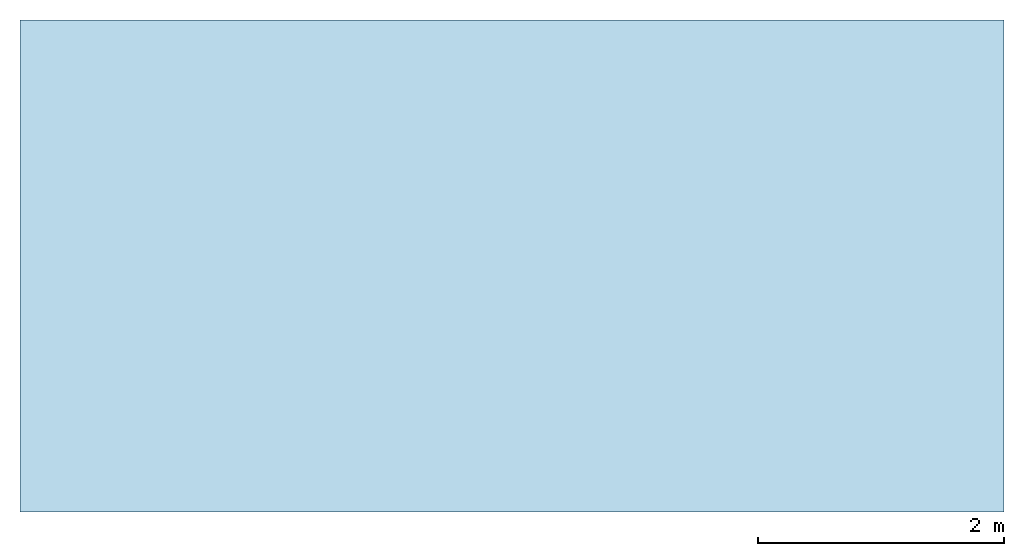
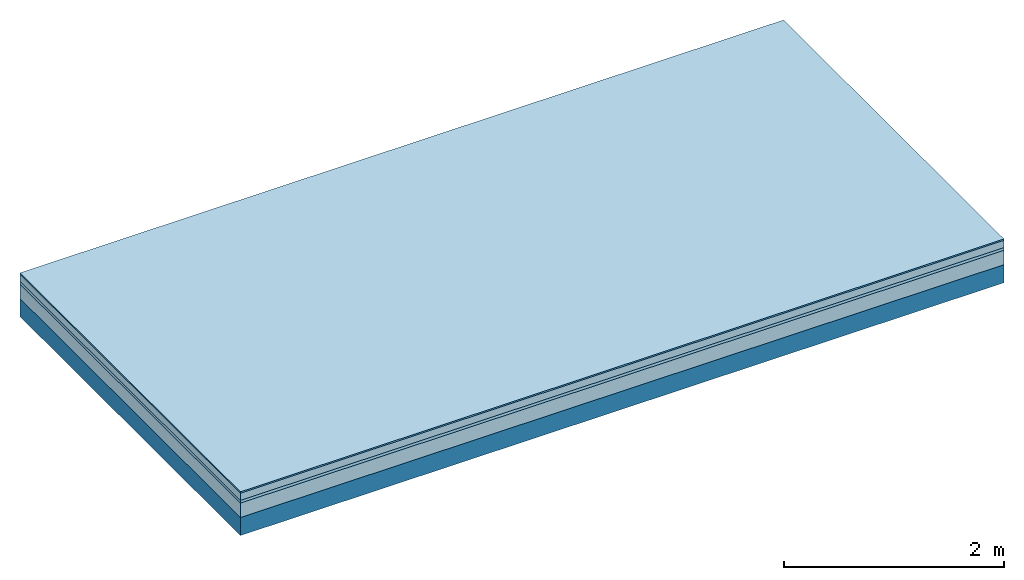
# One storey: 4 plates, 1 member, 1 element without a shape of its own.
"""IFC4 building model written with IfcOpenShell, lengths in metres."""

from ifc_helpers import new_model, si_unit, derived_unit, direction, frame, frame_2d, origin, origin_with_axes, place, context, project, spatial, rectangle, extrude, material, layer, layer_set, type_object, element, aggregate, save


model = new_model("IFC4")

# Units and contexts
plan_context = context("Plan", 3, precision=1e-05, world=origin(), true_north=direction((0.0, 1.0)))
model_context = context("Model", 3, precision=1e-05, world=origin(), true_north=direction((0.0, 1.0)))
ifc_project = project(units=[si_unit("LENGTHUNIT", "METRE"), derived_unit("SOUNDPRESSUREUNIT", [(si_unit("PRESSUREUNIT", "PASCAL", prefix="MICRO"), 0)]), si_unit("ENERGYUNIT", "JOULE", prefix="MEGA"), si_unit("MASSUNIT", "GRAM", prefix="KILO"), derived_unit("THERMALTRANSMITTANCEUNIT", [(si_unit("POWERUNIT", "WATT"), 1), (si_unit("AREAUNIT", "SQUARE_METRE"), -1), (si_unit("THERMODYNAMICTEMPERATUREUNIT", "KELVIN"), -1)]), derived_unit("AREADENSITYUNIT", [(si_unit("MASSUNIT", "GRAM", prefix="KILO"), 1), (si_unit("AREAUNIT", "SQUARE_METRE"), -1)]), derived_unit("USERDEFINED", [(si_unit("ENERGYUNIT", "JOULE", prefix="MEGA"), 1), (si_unit("AREAUNIT", "SQUARE_METRE"), -1)])], contexts=[plan_context, model_context])

# Site, building, storey
site = spatial("IfcSite", under=ifc_project)
building_placement = place(None, origin())
building = spatial("IfcBuilding", under=site, at=building_placement)
storey_placement = place(building_placement, origin())
storey = spatial("IfcBuildingStorey", under=building, at=storey_placement)

# Slab, member, plates
ifc_material_1 = material(Category="11.013")
ifc_layer_1 = layer(ifc_material_1, 0.015, Name="Flooring")
ifc_material_2 = material(Name="Cement screed", Category="04.006")
ifc_layer_2 = layer(ifc_material_2, 0.08, Name="On-material")
ifc_material_3 = material(Name="Wood fiber generic product", Category="10.009")
ifc_layer_3 = layer(ifc_material_3, 0.03, Name="Impact sound insulation")
ifc_material_4 = material(Category="01.002")
ifc_layer_4 = layer(ifc_material_4, 0.16, Name="Sub-floor")
ifc_material_5 = material(Name="Rigid, of the art")
ifc_layer_5 = layer(ifc_material_5, 0.0, Name="Bond")
ifc_layer_6 = layer(None, 0.2, Name="Supporting structure")
ifc_layer_set = layer_set([ifc_layer_1, ifc_layer_2, ifc_layer_3, ifc_layer_4, ifc_layer_5, ifc_layer_6])
slab_type = type_object("IfcSlabType", Name="A2213", PredefinedType="NOTDEFINED", material=ifc_layer_set)
slab_placement = place(None, frame((0.0, 0.0, 0.0), z_axis=(0.0, 0.0, -1.0), x_axis=(1.0, 0.0, 0.0)))
slab = element("IfcSlab", 1, at=slab_placement, inside=storey, type_object=slab_type, material=ifc_layer_set, Name="Slab #1")
ifc_material_6 = material(Name="Solid timber panel")
member_placement = place(slab_placement, origin())
member = element("IfcMember", 2, at=member_placement, material=ifc_material_6, Name="Supporting structure", context=plan_context, shape_type="SweptSolid", body=[
    extrude(rectangle(XDim=1.0, YDim=0.2, at=frame_2d((0.5, 0.1), x_axis=(1.0, 0.0))), frame((0.0, 4.0, 0.285), z_axis=(0.0, -1.0, 0.0), x_axis=(1.0, 0.0, 0.0)), (0.0, 0.0, 1.0), 4.0),
    extrude(rectangle(XDim=1.0, YDim=0.2, at=frame_2d((0.5, 0.1), x_axis=(1.0, 0.0))), frame((1.0, 4.0, 0.285), z_axis=(0.0, -1.0, 0.0), x_axis=(1.0, 0.0, 0.0)), (0.0, 0.0, 1.0), 4.0),
    extrude(rectangle(XDim=1.0, YDim=0.2, at=frame_2d((0.5, 0.1), x_axis=(1.0, 0.0))), frame((2.0, 4.0, 0.285), z_axis=(0.0, -1.0, 0.0), x_axis=(1.0, 0.0, 0.0)), (0.0, 0.0, 1.0), 4.0),
    extrude(rectangle(XDim=1.0, YDim=0.2, at=frame_2d((0.5, 0.1), x_axis=(1.0, 0.0))), frame((3.0, 4.0, 0.285), z_axis=(0.0, -1.0, 0.0), x_axis=(1.0, 0.0, 0.0)), (0.0, 0.0, 1.0), 4.0),
    extrude(rectangle(XDim=1.0, YDim=0.2, at=frame_2d((0.5, 0.1), x_axis=(1.0, 0.0))), frame((4.0, 4.0, 0.285), z_axis=(0.0, -1.0, 0.0), x_axis=(1.0, 0.0, 0.0)), (0.0, 0.0, 1.0), 4.0),
    extrude(rectangle(XDim=1.0, YDim=0.2, at=frame_2d((0.5, 0.1), x_axis=(1.0, 0.0))), frame((5.0, 4.0, 0.285), z_axis=(0.0, -1.0, 0.0), x_axis=(1.0, 0.0, 0.0)), (0.0, 0.0, 1.0), 4.0),
    extrude(rectangle(XDim=1.0, YDim=0.2, at=frame_2d((0.5, 0.1), x_axis=(1.0, 0.0))), frame((6.0, 4.0, 0.285), z_axis=(0.0, -1.0, 0.0), x_axis=(1.0, 0.0, 0.0)), (0.0, 0.0, 1.0), 4.0),
    extrude(rectangle(XDim=1.0, YDim=0.2, at=frame_2d((0.5, 0.1), x_axis=(1.0, 0.0))), frame((7.0, 4.0, 0.285), z_axis=(0.0, -1.0, 0.0), x_axis=(1.0, 0.0, 0.0)), (0.0, 0.0, 1.0), 4.0),
])
plate_1_placement = place(slab_placement, origin())
plate_1 = element("IfcPlate", 3, at=plate_1_placement, material=ifc_material_1, Name="Flooring", context=plan_context, shape_type="SweptSolid", body=[
    extrude(rectangle(XDim=8.0, YDim=4.0, at=frame_2d((4.0, 2.0), x_axis=(1.0, 0.0))), origin_with_axes(), (0.0, 0.0, 1.0), 0.015),
])
plate_2_placement = place(slab_placement, origin())
plate_2 = element("IfcPlate", 4, at=plate_2_placement, material=ifc_material_2, Name="On-material", context=plan_context, shape_type="SweptSolid", body=[
    extrude(rectangle(XDim=8.0, YDim=4.0, at=frame_2d((4.0, 2.0), x_axis=(1.0, 0.0))), frame((0.0, 0.0, 0.015), z_axis=(0.0, 0.0, 1.0), x_axis=(1.0, 0.0, 0.0)), (0.0, 0.0, 1.0), 0.08),
])
plate_3_placement = place(slab_placement, origin())
plate_3 = element("IfcPlate", 5, at=plate_3_placement, material=ifc_material_3, Name="Impact sound insulation", context=plan_context, shape_type="SweptSolid", body=[
    extrude(rectangle(XDim=8.0, YDim=4.0, at=frame_2d((4.0, 2.0), x_axis=(1.0, 0.0))), frame((0.0, 0.0, 0.095), z_axis=(0.0, 0.0, 1.0), x_axis=(1.0, 0.0, 0.0)), (0.0, 0.0, 1.0), 0.03),
])
plate_4_placement = place(slab_placement, origin())
plate_4 = element("IfcPlate", 6, at=plate_4_placement, material=ifc_material_4, Name="Sub-floor", context=plan_context, shape_type="SweptSolid", body=[
    extrude(rectangle(XDim=8.0, YDim=4.0, at=frame_2d((4.0, 2.0), x_axis=(1.0, 0.0))), frame((0.0, 0.0, 0.125), z_axis=(0.0, 0.0, 1.0), x_axis=(1.0, 0.0, 0.0)), (0.0, 0.0, 1.0), 0.16),
])
aggregate(slab, [plate_1, plate_2, plate_3, plate_4, member])

save(model, "model.ifc")
